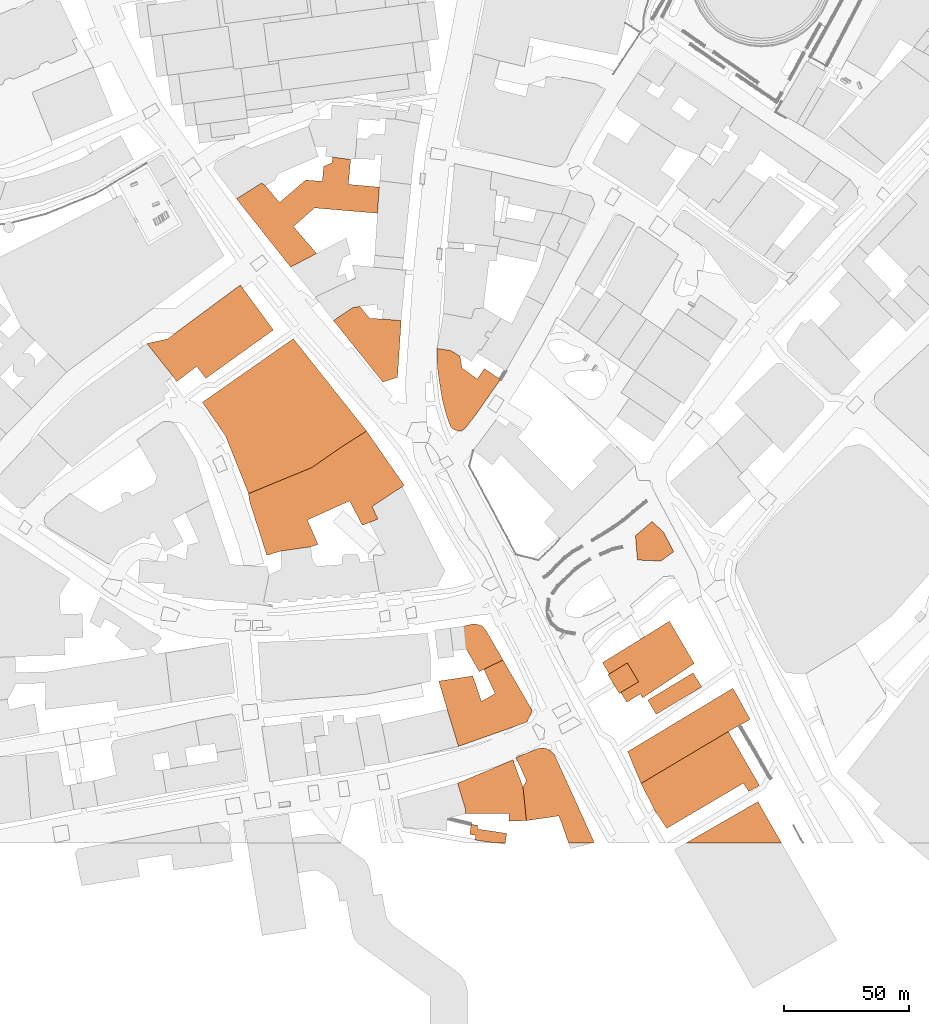
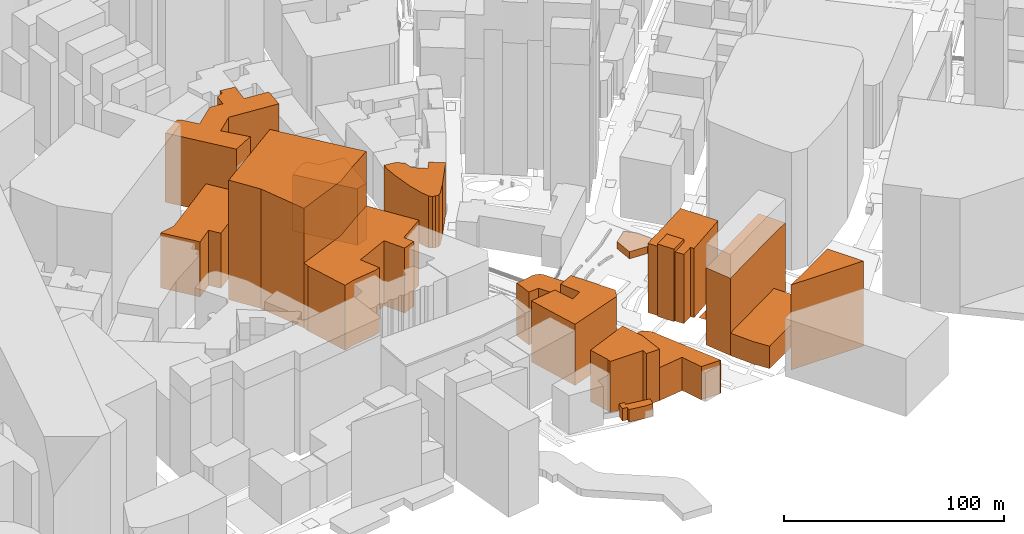
# One storey, part 101 of 200: 18 proxies.
"""IFC4 building model written with IfcOpenShell, lengths in metres."""

from ifc_helpers import new_model, si_unit, origin_with_axes, place, context, subcontext, project, spatial, triangles, material, element, save


model = new_model("IFC4")

# Units and contexts
model_context = context("Model", 3, precision=1e-05, world=origin_with_axes())
body_context = subcontext(model_context, "Body", "Model", "MODEL_VIEW")
ifc_project = project(units=[si_unit("VOLUMEUNIT", "CUBIC_METRE"), si_unit("LENGTHUNIT", "METRE"), si_unit("AREAUNIT", "SQUARE_METRE")], contexts=[model_context])

# Site, building, storey
site_placement = place(None, origin_with_axes())
site = spatial("IfcSite", under=ifc_project, at=site_placement)
building_placement = place(site_placement, origin_with_axes())
building = spatial("IfcBuilding", under=site, at=building_placement, Name="Building")
storey_placement = place(building_placement, origin_with_axes())
storey = spatial("IfcBuildingStorey", under=building, at=storey_placement, Name="Ground")

# Proxies
ifc_material_1 = material()
proxy_1_placement = place(storey_placement, origin_with_axes())
element("IfcBuildingElementProxy", 1, at=proxy_1_placement, inside=storey, material=ifc_material_1, Name="cw_buildings_UK 442", context=body_context, shape_type="Tessellation", body=[
    triangles([(348.2929526134377, -713.8784918243783, 31.215002059936523), (342.9966887310573, -688.4192587580843, 31.215002059936523), (339.09418499970246, -683.6805008354617, 31.215002059936523), (328.5945733121118, -689.3484195297851, 31.215002059936523), (355.6333986837714, -689.3484195297851, 31.215002059936523), (336.30667419438856, -684.145081221312, 31.215002059936523), (333.5191633890746, -695.4809376034334, 31.215002059936523), (354.1467224555758, -711.9272352103322, 31.215002059936523), (348.01420438192747, -688.6980069895945, 31.215002059936523), (354.1467224555758, -711.9272352103322, 0.0), (355.6333986837714, -689.3484195297851, 0.0), (348.2929526134377, -713.8784918243783, 0.0), (333.5191633890746, -695.4809376034334, 0.0), (328.5945733121118, -689.3484195297851, 0.0), (336.30667419438856, -684.145081221312, 0.0), (339.09418499970246, -683.6805008354617, 0.0), (342.9966887310573, -688.4192587580843, 0.0), (348.01420438192747, -688.6980069895945, 0.0)], [[1, 2, 3], [3, 4, 1], [1, 5, 2], [3, 6, 4], [4, 7, 1], [1, 8, 5], [5, 9, 2], [10, 11, 5], [10, 5, 8], [12, 10, 8], [12, 8, 1], [13, 12, 1], [13, 1, 7], [14, 13, 7], [14, 7, 4], [15, 14, 4], [15, 4, 6], [16, 15, 6], [16, 6, 3], [17, 16, 3], [17, 3, 2], [18, 17, 2], [18, 2, 9], [11, 18, 9], [11, 9, 5], [17, 18, 11], [11, 10, 12], [12, 13, 14], [14, 15, 16], [17, 11, 12], [12, 14, 16], [16, 17, 12]], closed=False),
])
proxy_2_placement = place(storey_placement, origin_with_axes())
element("IfcBuildingElementProxy", 2, at=proxy_2_placement, inside=storey, material=ifc_material_1, Name="cw_buildings_UK 443", context=body_context, shape_type="Tessellation", body=[
    triangles([(307.0378439771726, -642.2395505481192, 38.31364059448242), (321.0682998358065, -644.3766393165054, 38.31364059448242), (334.54124973468265, -634.9920205549555, 38.31364059448242), (324.134554124262, -633.7841115517446, 38.31364059448242), (312.61286083943185, -651.8099824705347, 38.31364059448242), (335.47042000312064, -625.0499243238597, 38.31364059448242), (299.9296975965013, -634.434524091935, 38.31364059448242), (346.1558638450515, -646.5137280848915, 38.31364059448242), (328.0370673523541, -626.3507494042407, 38.31364059448242), (311.49785841665374, -667.9775318459233, 38.31364059448242), (346.89920195914937, -636.1070324744709, 38.31364059448242), (328.2228995066942, -624.1207445586845, 38.31364059448242), (324.6920600840197, -627.8374256324364, 38.31364059448242), (317.53745566476334, -633.2265960952496, 38.31364059448242), (301.41636907632835, -635.4566199342803, 38.31364059448242), (289.89467104312956, -640.7528743199235, 38.31364059448242), (321.88132025941326, -662.5418843510506, 38.31364059448242), (289.89467104312956, -640.7528743199235, 0.0), (311.49785841665374, -667.9775318459233, 0.0), (299.9296975965013, -634.434524091935, 0.0), (301.41636907632835, -635.4566199342803, 0.0), (307.0378439771726, -642.2395505481192, 0.0), (317.53745566476334, -633.2265960952496, 0.0), (324.134554124262, -633.7841115517446, 0.0), (324.6920600840197, -627.8374256324364, 0.0), (328.0370673523541, -626.3507494042407, 0.0), (328.2228995066942, -624.1207445586845, 0.0), (335.47042000312064, -625.0499243238597, 0.0), (334.54124973468265, -634.9920205549555, 0.0), (346.89920195914937, -636.1070324744709, 0.0), (346.1558638450515, -646.5137280848915, 0.0), (321.0682998358065, -644.3766393165054, 0.0), (312.61286083943185, -651.8099824705347, 0.0), (321.88132025941326, -662.5418843510506, 0.0)], [[1, 2, 3], [3, 4, 1], [1, 5, 2], [3, 6, 4], [1, 7, 5], [2, 8, 3], [6, 9, 4], [7, 10, 5], [8, 11, 3], [6, 12, 9], [9, 13, 4], [4, 14, 1], [1, 15, 7], [7, 16, 10], [10, 17, 5], [18, 19, 10], [18, 10, 16], [20, 18, 16], [20, 16, 7], [21, 20, 7], [21, 7, 15], [22, 21, 15], [22, 15, 1], [23, 22, 1], [23, 1, 14], [24, 23, 14], [24, 14, 4], [25, 24, 4], [25, 4, 13], [26, 25, 13], [26, 13, 9], [27, 26, 9], [27, 9, 12], [28, 27, 12], [28, 12, 6], [29, 28, 6], [29, 6, 3], [30, 29, 3], [30, 3, 11], [31, 30, 11], [31, 11, 8], [32, 31, 8], [32, 8, 2], [33, 32, 2], [33, 2, 5], [34, 33, 5], [34, 5, 17], [19, 34, 17], [19, 17, 10], [33, 34, 19], [19, 18, 20], [20, 21, 22], [22, 23, 24], [24, 25, 26], [26, 27, 28], [29, 30, 31], [33, 19, 20], [24, 26, 28], [29, 31, 32], [33, 20, 22], [24, 28, 29], [32, 33, 22], [22, 24, 29], [29, 32, 22]], closed=False),
])
proxy_3_placement = place(storey_placement, origin_with_axes())
element("IfcBuildingElementProxy", 3, at=proxy_3_placement, inside=storey, material=ifc_material_1, Name="cw_buildings_UK 447", context=body_context, shape_type="Tessellation", body=[
    triangles([(262.34480487285015, -696.6888656001188, 30.53400230407715), (264.5748120925907, -711.555570901652, 30.53400230407715), (274.0523374345734, -707.5601415963898, 30.53400230407715), (304.6220022289076, -693.065100603537, 30.53400230407715), (254.1681152950779, -698.4542900598248, 30.53400230407715), (266.0614811982334, -713.6926596700381, 30.53400230407715), (277.67609768278663, -712.3918155961826, 30.53400230407715), (291.42780056154163, -675.1321267684424, 30.53400230407715), (304.6220022289076, -693.065100603537, 0.0), (291.42780056154163, -675.1321267684424, 0.0), (277.67609768278663, -712.3918155961826, 0.0), (274.0523374345734, -707.5601415963898, 0.0), (266.0614811982334, -713.6926596700381, 0.0), (264.5748120925907, -711.555570901652, 0.0), (254.1681152950779, -698.4542900598248, 0.0), (262.34480487285015, -696.6888656001188, 0.0)], [[1, 2, 3], [3, 4, 1], [1, 5, 2], [2, 6, 3], [3, 7, 4], [4, 8, 1], [9, 10, 8], [9, 8, 4], [11, 9, 4], [11, 4, 7], [12, 11, 7], [12, 7, 3], [13, 12, 3], [13, 3, 6], [14, 13, 6], [14, 6, 2], [15, 14, 2], [15, 2, 5], [16, 15, 5], [16, 5, 1], [10, 16, 1], [10, 1, 8], [16, 10, 9], [9, 11, 12], [12, 13, 14], [14, 15, 16], [16, 9, 12], [12, 14, 16]], closed=False),
])
proxy_4_placement = place(storey_placement, origin_with_axes())
element("IfcBuildingElementProxy", 4, at=proxy_4_placement, inside=storey, material=ifc_material_1, Name="cw_buildings_UK 450", context=body_context, shape_type="Tessellation", body=[
    triangles([(318.1878729533225, -768.8853223328729, 35.946388244628906), (335.0058396172703, -761.2661280310289, 35.946388244628906), (319.95329741302834, -747.9790150348615, 35.946388244628906), (307.5953451885617, -781.2897325959246, 35.946388244628906), (344.01877507666535, -763.4961138831106, 35.946388244628906), (295.0980188483399, -761.405502146784, 35.946388244628906), (319.58162835597943, -779.5707471813292, 35.946388244628906), (342.9734597117648, -769.8609411431587, 35.946388244628906), (341.7887702311091, -733.3910389713641, 35.946388244628906), (294.70312077199844, -758.3624816259896, 35.946388244628906), (301.99709930700993, -782.985469997753, 35.946388244628906), (322.46205523846345, -778.6415864096285, 35.946388244628906), (340.1162713453105, -771.0223921077845, 35.946388244628906), (346.3417054961289, -768.5136580241926, 35.946388244628906), (356.84131718371964, -755.040674886736, 35.946388244628906), (332.0324966576162, -739.6164921156569, 35.946388244628906), (356.84131718371964, -755.040674886736, 0.0), (341.7887702311091, -733.3910389713641, 0.0), (344.01877507666535, -763.4961138831106, 0.0), (346.3417054961289, -768.5136580241926, 0.0), (342.9734597117648, -769.8609411431587, 0.0), (340.1162713453105, -771.0223921077845, 0.0), (335.0058396172703, -761.2661280310289, 0.0), (318.1878729533225, -768.8853223328729, 0.0), (322.46205523846345, -778.6415864096285, 0.0), (319.58162835597943, -779.5707471813292, 0.0), (307.5953451885617, -781.2897325959246, 0.0), (301.99709930700993, -782.985469997753, 0.0), (295.0980188483399, -761.405502146784, 0.0), (294.70312077199844, -758.3624816259896, 0.0), (319.95329741302834, -747.9790150348615, 0.0), (332.0324966576162, -739.6164921156569, 0.0)], [[1, 2, 3], [3, 4, 1], [2, 5, 3], [3, 6, 4], [4, 7, 1], [2, 8, 5], [5, 9, 3], [3, 10, 6], [6, 11, 4], [7, 12, 1], [2, 13, 8], [8, 14, 5], [5, 15, 9], [9, 16, 3], [17, 18, 9], [17, 9, 15], [19, 17, 15], [19, 15, 5], [20, 19, 5], [20, 5, 14], [21, 20, 14], [21, 14, 8], [22, 21, 8], [22, 8, 13], [23, 22, 13], [23, 13, 2], [24, 23, 2], [24, 2, 1], [25, 24, 1], [25, 1, 12], [26, 25, 12], [26, 12, 7], [27, 26, 7], [27, 7, 4], [28, 27, 4], [28, 4, 11], [29, 28, 11], [29, 11, 6], [30, 29, 6], [30, 6, 10], [31, 30, 10], [31, 10, 3], [32, 31, 3], [32, 3, 16], [18, 32, 16], [18, 16, 9], [31, 32, 18], [18, 17, 19], [19, 20, 21], [21, 22, 23], [24, 25, 26], [27, 28, 29], [29, 30, 31], [31, 18, 19], [19, 21, 23], [24, 26, 27], [27, 29, 31], [31, 19, 23], [24, 27, 31], [31, 23, 24]], closed=False),
])
proxy_5_placement = place(storey_placement, origin_with_axes())
element("IfcBuildingElementProxy", 5, at=proxy_5_placement, inside=storey, material=ifc_material_1, Name="cw_buildings_UK 454", context=body_context, shape_type="Tessellation", body=[
    triangles([(381.0926317500654, -732.3689621224933, 28.69000244140625), (379.9079422694097, -708.2802411944579, 28.69000244140625), (369.8496819483768, -704.679724210643, 28.69000244140625), (375.3317779850974, -731.8114656594728, 28.69000244140625), (385.994002304473, -712.6705638276928, 28.69000244140625), (379.09491709743435, -703.6111703297128, 28.69000244140625), (371.98677071676303, -720.8472545925573, 28.69000244140625), (378.1192887904113, -733.298122894194, 28.69000244140625), (395.19276991820817, -712.833185956215, 28.69000244140625), (369.9425980255469, -700.4984627510408, 28.69000244140625), (370.31427183096446, -710.2547268277965, 28.69000244140625), (373.7521951764689, -727.4443720455304, 28.69000244140625), (376.72553813612296, -732.9264585855137, 28.69000244140625), (379.7917971729471, -733.298122894194, 28.69000244140625), (385.2971222289602, -727.0030016854981, 28.69000244140625), (388.78150361304967, -708.4428443295055, 28.69000244140625), (375.3317779850974, -701.2417913684014, 28.69000244140625), (369.8961399869619, -702.2638682172721, 28.69000244140625), (375.3317779850974, -701.2417913684014, 0.0), (369.9425980255469, -700.4984627510408, 0.0), (379.09491709743435, -703.6111703297128, 0.0), (379.9079422694097, -708.2802411944579, 0.0), (385.994002304473, -712.6705638276928, 0.0), (388.78150361304967, -708.4428443295055, 0.0), (395.19276991820817, -712.833185956215, 0.0), (385.2971222289602, -727.0030016854981, 0.0), (381.0926317500654, -732.3689621224933, 0.0), (379.7917971729471, -733.298122894194, 0.0), (378.1192887904113, -733.298122894194, 0.0), (376.72553813612296, -732.9264585855137, 0.0), (375.3317779850974, -731.8114656594728, 0.0), (373.7521951764689, -727.4443720455304, 0.0), (371.98677071676303, -720.8472545925573, 0.0), (370.31427183096446, -710.2547268277965, 0.0), (369.8496819483768, -704.679724210643, 0.0), (369.8961399869619, -702.2638682172721, 0.0)], [[1, 2, 3], [3, 4, 1], [1, 5, 2], [2, 6, 3], [3, 7, 4], [4, 8, 1], [1, 9, 5], [6, 10, 3], [3, 11, 7], [7, 12, 4], [4, 13, 8], [8, 14, 1], [1, 15, 9], [9, 16, 5], [6, 17, 10], [10, 18, 3], [19, 20, 10], [19, 10, 17], [21, 19, 17], [21, 17, 6], [22, 21, 6], [22, 6, 2], [23, 22, 2], [23, 2, 5], [24, 23, 5], [24, 5, 16], [25, 24, 16], [25, 16, 9], [26, 25, 9], [26, 9, 15], [27, 26, 15], [27, 15, 1], [28, 27, 1], [28, 1, 14], [29, 28, 14], [29, 14, 8], [30, 29, 8], [30, 8, 13], [31, 30, 13], [31, 13, 4], [32, 31, 4], [32, 4, 12], [33, 32, 12], [33, 12, 7], [34, 33, 7], [34, 7, 11], [35, 34, 11], [35, 11, 3], [36, 35, 3], [36, 3, 18], [20, 36, 18], [20, 18, 10], [35, 36, 20], [20, 19, 21], [23, 24, 25], [25, 26, 27], [27, 28, 29], [29, 30, 31], [31, 32, 33], [33, 34, 35], [35, 20, 21], [23, 25, 27], [27, 29, 31], [31, 33, 35], [35, 21, 22], [22, 23, 27], [27, 31, 35], [35, 22, 27]], closed=False),
])
proxy_6_placement = place(storey_placement, origin_with_axes())
element("IfcBuildingElementProxy", 6, at=proxy_6_placement, inside=storey, material=ifc_material_1, Name="cw_buildings_UK 511", context=body_context, shape_type="Tessellation", body=[
    triangles([(464.29973859484556, -781.5452328146678, 3.910000801086426), (455.70492548271585, -769.4892768344783, 3.910000801086426), (449.87438465987026, -784.8670015669725, 3.910000801086426), (459.1892973700681, -785.2851619011867, 3.910000801086426), (460.327538308876, -773.7634543712508, 3.910000801086426), (449.08457901045017, -775.1571955288018, 3.910000801086426), (460.327538308876, -773.7634543712508, 0.0), (455.70492548271585, -769.4892768344783, 0.0), (464.29973859484556, -781.5452328146678, 0.0), (459.1892973700681, -785.2851619011867, 0.0), (449.87438465987026, -784.8670015669725, 0.0), (449.08457901045017, -775.1571955288018, 0.0)], [[1, 2, 3], [3, 4, 1], [1, 5, 2], [2, 6, 3], [7, 8, 2], [7, 2, 5], [9, 7, 5], [9, 5, 1], [10, 9, 1], [10, 1, 4], [11, 10, 4], [11, 4, 3], [12, 11, 3], [12, 3, 6], [8, 12, 6], [8, 6, 2], [11, 12, 8], [8, 7, 9], [9, 10, 11], [11, 8, 9]], closed=False),
])
proxy_7_placement = place(storey_placement, origin_with_axes())
element("IfcBuildingElementProxy", 7, at=proxy_7_placement, inside=storey, material=ifc_material_1, Name="cw_buildings_UK 519", context=body_context, shape_type="Tessellation", body=[
    triangles([(341.7887702311091, -733.3910389713641, 66.19275665283203), (285.4811193906021, -735.2958565402996, 66.19275665283203), (294.70312077199844, -758.3624816259896, 66.19275665283203), (332.0324966576162, -739.6164921156569, 66.19275665283203), (276.3055712994222, -721.9390374927801, 66.19275665283203), (319.95329741302834, -747.9790150348615, 66.19275665283203), (312.56640280084684, -696.5262624650712, 66.19275665283203), (332.0324966576162, -739.6164921156569, 0.0), (341.7887702311091, -733.3910389713641, 0.0), (319.95329741302834, -747.9790150348615, 0.0), (294.70312077199844, -758.3624816259896, 0.0), (285.4811193906021, -735.2958565402996, 0.0), (276.3055712994222, -721.9390374927801, 0.0), (312.56640280084684, -696.5262624650712, 0.0)], [[1, 2, 3], [3, 4, 1], [1, 5, 2], [3, 6, 4], [1, 7, 5], [8, 9, 1], [8, 1, 4], [10, 8, 4], [10, 4, 6], [11, 10, 6], [11, 6, 3], [12, 11, 3], [12, 3, 2], [13, 12, 2], [13, 2, 5], [14, 13, 5], [14, 5, 7], [9, 14, 7], [9, 7, 1], [13, 14, 9], [8, 10, 11], [12, 13, 9], [9, 8, 11], [11, 12, 9]], closed=False),
])
proxy_8_placement = place(storey_placement, origin_with_axes())
element("IfcBuildingElementProxy", 8, at=proxy_8_placement, inside=storey, material=ifc_material_1, Name="cw_buildings_UK 711", context=body_context, shape_type="Tessellation", body=[
    triangles([(451.9185573510864, -815.9419229815255, 38.32500076293945), (440.39684982115034, -834.4091595119794, 38.32500076293945), (451.0126066052037, -838.2884437207789, 38.32500076293945), (451.9417863703789, -839.868031277776, 38.32500076293945), (438.654654380737, -830.2743608393307, 38.32500076293945), (443.2308281617866, -837.7077134900974, 38.32500076293945), (462.60400119301727, -809.2519060706725, 38.32500076293945), (435.8903820914528, -825.7911173805571, 38.32500076293945), (438.0971579177166, -830.6227961287185, 38.32500076293945), (442.6036256474141, -838.1026068180702, 38.32500076293945), (445.62343614239046, -841.6102219698207, 38.32500076293945), (472.54611641758754, -826.1627840634218, 38.32500076293945), (451.0126066052037, -838.2884437207789, 0.0), (451.9417863703789, -839.868031277776, 0.0), (445.62343614239046, -841.6102219698207, 0.0), (443.2308281617866, -837.7077134900974, 0.0), (442.6036256474141, -838.1026068180702, 0.0), (440.39684982115034, -834.4091595119794, 0.0), (438.0971579177166, -830.6227961287185, 0.0), (438.654654380737, -830.2743608393307, 0.0), (435.8903820914528, -825.7911173805571, 0.0), (451.9185573510864, -815.9419229815255, 0.0), (462.60400119301727, -809.2519060706725, 0.0), (472.54611641758754, -826.1627840634218, 0.0)], [[1, 2, 3], [3, 4, 1], [1, 5, 2], [2, 6, 3], [4, 7, 1], [1, 8, 5], [5, 9, 2], [2, 10, 6], [6, 11, 3], [4, 12, 7], [13, 14, 4], [13, 4, 3], [15, 13, 3], [15, 3, 11], [16, 15, 11], [16, 11, 6], [17, 16, 6], [17, 6, 10], [18, 17, 10], [18, 10, 2], [19, 18, 2], [19, 2, 9], [20, 19, 9], [20, 9, 5], [21, 20, 5], [21, 5, 8], [22, 21, 8], [22, 8, 1], [23, 22, 1], [23, 1, 7], [24, 23, 7], [24, 7, 12], [14, 24, 12], [14, 12, 4], [23, 24, 14], [13, 15, 16], [16, 17, 18], [18, 19, 20], [20, 21, 22], [22, 23, 14], [13, 16, 18], [18, 20, 22], [22, 14, 13], [13, 18, 22]], closed=False),
])
proxy_9_placement = place(storey_placement, origin_with_axes())
element("IfcBuildingElementProxy", 9, at=proxy_9_placement, inside=storey, material=ifc_material_1, Name="cw_buildings_UK 712", context=body_context, shape_type="Tessellation", body=[
    triangles([(494.86939389244253, -848.4628443899057, 42.794002532958984), (445.97187143177825, -861.2853817485915, 42.794002532958984), (486.1584356838502, -853.2480650994821, 42.794002532958984), (490.5719873363777, -850.8322280995858, 42.794002532958984), (487.9703181821411, -835.9887470689765, 42.794002532958984), (451.2913738301884, -874.0149982817384, 42.794002532958984), (487.9703181821411, -835.9887470689765, 0.0), (445.97187143177825, -861.2853817485915, 0.0), (494.86939389244253, -848.4628443899057, 0.0), (490.5719873363777, -850.8322280995858, 0.0), (486.1584356838502, -853.2480650994821, 0.0), (451.2913738301884, -874.0149982817384, 0.0)], [[1, 2, 3], [3, 4, 1], [1, 5, 2], [2, 6, 3], [7, 8, 2], [7, 2, 5], [9, 7, 5], [9, 5, 1], [10, 9, 1], [10, 1, 4], [11, 10, 4], [11, 4, 3], [12, 11, 3], [12, 3, 6], [8, 12, 6], [8, 6, 2], [11, 12, 8], [8, 7, 9], [9, 10, 11], [11, 8, 9]], closed=False),
])
proxy_10_placement = place(storey_placement, origin_with_axes())
element("IfcBuildingElementProxy", 10, at=proxy_10_placement, inside=storey, material=ifc_material_1, Name="cw_buildings_UK 720", context=body_context, shape_type="Tessellation", body=[
    triangles([(398.6074737411574, -886.0709732554024, 28.537002563476562), (398.70038981832744, -888.9513906411491, 28.537002563476562), (400.2102855690784, -864.5839309783407, 28.537002563476562), (381.2320058658205, -884.2126327185264, 28.537002563476562), (405.5994750253661, -888.8352455446865, 28.537002563476562), (381.32492194299056, -886.0709732554024, 28.537002563476562), (402.3938323760496, -888.904932602564, 28.537002563476562), (404.2057148743405, -875.4552069746118, 28.537002563476562), (378.1192887904113, -873.8756241659833, 28.537002563476562), (400.2102855690784, -864.5839309783407, 0.0), (378.1192887904113, -873.8756241659833, 0.0), (404.2057148743405, -875.4552069746118, 0.0), (405.5994750253661, -888.8352455446865, 0.0), (402.3938323760496, -888.904932602564, 0.0), (398.70038981832744, -888.9513906411491, 0.0), (398.6074737411574, -886.0709732554024, 0.0), (381.32492194299056, -886.0709732554024, 0.0), (381.2320058658205, -884.2126327185264, 0.0)], [[1, 2, 3], [3, 4, 1], [2, 5, 3], [4, 6, 1], [2, 7, 5], [5, 8, 3], [3, 9, 4], [10, 11, 9], [10, 9, 3], [12, 10, 3], [12, 3, 8], [13, 12, 8], [13, 8, 5], [14, 13, 5], [14, 5, 7], [15, 14, 7], [15, 7, 2], [16, 15, 2], [16, 2, 1], [17, 16, 1], [17, 1, 6], [18, 17, 6], [18, 6, 4], [11, 18, 4], [11, 4, 9], [18, 11, 10], [10, 12, 13], [13, 14, 15], [16, 17, 18], [10, 13, 15], [16, 18, 10], [10, 15, 16]], closed=False),
])
proxy_11_placement = place(storey_placement, origin_with_axes())
element("IfcBuildingElementProxy", 11, at=proxy_11_placement, inside=storey, material=ifc_material_1, Name="cw_buildings_UK 728", context=body_context, shape_type="Tessellation", body=[
    triangles([(486.73916116616317, -854.4095303092139, 12.42500114440918), (486.1584356838502, -853.2480650994821, 12.42500114440918), (492.1748086610359, -873.8988531852758, 12.42500114440918), (495.45013836823, -869.4620725134558, 12.42500114440918), (456.81991840875673, -884.8165872201319, 12.42500114440918), (498.5860749661945, -874.8047944344213, 12.42500114440918), (490.362926162745, -860.5885064214473, 12.42500114440918), (451.2913738301884, -874.0149982817384, 12.42500114440918), (461.55867633137944, -891.9247336008032, 12.42500114440918), (494.26543939083706, -877.2206314343176, 12.42500114440918), (461.55867633137944, -891.9247336008032, 0.0), (492.1748086610359, -873.8988531852758, 0.0), (456.81991840875673, -884.8165872201319, 0.0), (451.2913738301884, -874.0149982817384, 0.0), (486.1584356838502, -853.2480650994821, 0.0), (486.73916116616317, -854.4095303092139, 0.0), (490.362926162745, -860.5885064214473, 0.0), (495.45013836823, -869.4620725134558, 0.0), (498.5860749661945, -874.8047944344213, 0.0), (494.26543939083706, -877.2206314343176, 0.0)], [[1, 2, 3], [3, 4, 1], [2, 5, 3], [3, 6, 4], [4, 7, 1], [2, 8, 5], [5, 9, 3], [3, 10, 6], [11, 12, 3], [11, 3, 9], [13, 11, 9], [13, 9, 5], [14, 13, 5], [14, 5, 8], [15, 14, 8], [15, 8, 2], [16, 15, 2], [16, 2, 1], [17, 16, 1], [17, 1, 7], [18, 17, 7], [18, 7, 4], [19, 18, 4], [19, 4, 6], [20, 19, 6], [20, 6, 10], [12, 20, 10], [12, 10, 3], [19, 20, 12], [12, 11, 13], [13, 14, 15], [16, 17, 18], [18, 19, 12], [12, 13, 15], [16, 18, 12], [12, 15, 16]], closed=False),
])
proxy_12_placement = place(storey_placement, origin_with_axes())
element("IfcBuildingElementProxy", 12, at=proxy_12_placement, inside=storey, material=ifc_material_1, Name="cw_buildings_UK 729", context=body_context, shape_type="Tessellation", body=[
    triangles([(405.92468129546137, -849.4849307355138, 33.8280029296875), (393.1021391884071, -838.1722986243163, 33.8280029296875), (387.6200431516865, -841.2385529127719, 33.8280029296875), (373.93802733080906, -844.4209617944272, 33.8280029296875), (396.2380852831088, -824.7225729963641, 33.8280029296875), (384.1821198061821, -831.11061028223, 33.8280029296875), (407.8759379095074, -844.8623131609851, 33.8280029296875), (388.61890047800205, -828.4624783410399, 33.8280029296875), (370.6162490817672, -833.1547829734461, 33.8280029296875), (378.4677240797991, -859.1947510187903, 33.8280029296875), (384.1821198061821, -831.11061028223, 0.0), (370.6162490817672, -833.1547829734461, 0.0), (387.6200431516865, -841.2385529127719, 0.0), (393.1021391884071, -838.1722986243163, 0.0), (388.61890047800205, -828.4624783410399, 0.0), (396.2380852831088, -824.7225729963641, 0.0), (407.8759379095074, -844.8623131609851, 0.0), (405.92468129546137, -849.4849307355138, 0.0), (378.4677240797991, -859.1947510187903, 0.0), (373.93802733080906, -844.4209617944272, 0.0)], [[1, 2, 3], [3, 4, 1], [1, 5, 2], [3, 6, 4], [1, 7, 5], [5, 8, 2], [6, 9, 4], [4, 10, 1], [11, 12, 9], [11, 9, 6], [13, 11, 6], [13, 6, 3], [14, 13, 3], [14, 3, 2], [15, 14, 2], [15, 2, 8], [16, 15, 8], [16, 8, 5], [17, 16, 5], [17, 5, 7], [18, 17, 7], [18, 7, 1], [19, 18, 1], [19, 1, 10], [20, 19, 10], [20, 10, 4], [12, 20, 4], [12, 4, 9], [18, 19, 20], [20, 12, 11], [14, 15, 16], [16, 17, 18], [20, 11, 13], [14, 16, 18], [18, 20, 13], [13, 14, 18]], closed=False),
])
proxy_13_placement = place(storey_placement, origin_with_axes())
element("IfcBuildingElementProxy", 13, at=proxy_13_placement, inside=storey, material=ifc_material_1, Name="cw_buildings_UK 731", context=body_context, shape_type="Tessellation", body=[
    triangles([(389.2693225149298, -812.6433737517762, 29.238000869750977), (380.7209674413851, -811.1799312912417, 29.238000869750977), (381.65012821308585, -820.5180825174692, 29.238000869750977), (386.7605599411261, -829.3684195901853, 29.238000869750977), (386.0172313237655, -810.5062826092058, 29.238000869750977), (375.2156328886348, -811.9464960504478, 29.238000869750977), (396.2380852831088, -824.7225729963641, 29.238000869750977), (387.87556236390424, -811.1567022719491, 29.238000869750977), (384.25180686405963, -810.3204504548655, 29.238000869750977), (376.35386433070545, -821.0523547095657, 29.238000869750977), (380.7209674413851, -811.1799312912417, 0.0), (375.2156328886348, -811.9464960504478, 0.0), (384.25180686405963, -810.3204504548655, 0.0), (386.0172313237655, -810.5062826092058, 0.0), (387.87556236390424, -811.1567022719491, 0.0), (389.2693225149298, -812.6433737517762, 0.0), (396.2380852831088, -824.7225729963641, 0.0), (386.7605599411261, -829.3684195901853, 0.0), (381.65012821308585, -820.5180825174692, 0.0), (376.35386433070545, -821.0523547095657, 0.0)], [[1, 2, 3], [3, 4, 1], [1, 5, 2], [2, 6, 3], [4, 7, 1], [1, 8, 5], [5, 9, 2], [6, 10, 3], [11, 12, 6], [11, 6, 2], [13, 11, 2], [13, 2, 9], [14, 13, 9], [14, 9, 5], [15, 14, 5], [15, 5, 8], [16, 15, 8], [16, 8, 1], [17, 16, 1], [17, 1, 7], [18, 17, 7], [18, 7, 4], [19, 18, 4], [19, 4, 3], [20, 19, 3], [20, 3, 10], [12, 20, 10], [12, 10, 6], [19, 20, 12], [11, 13, 14], [14, 15, 16], [16, 17, 18], [19, 12, 11], [11, 14, 16], [16, 18, 19], [19, 11, 16]], closed=False),
])
proxy_14_placement = place(storey_placement, origin_with_axes())
element("IfcBuildingElementProxy", 14, at=proxy_14_placement, inside=storey, material=ifc_material_1, Name="cw_buildings_UK 732", context=body_context, shape_type="Tessellation", body=[
    triangles([(450.33896504572067, -833.433535953325, 40.12200164794922), (438.654654380737, -830.2743608393307, 40.12200164794922), (440.39684982115034, -834.4091595119794, 40.12200164794922), (443.2308281617866, -837.7077134900974, 40.12200164794922), (445.83249731602314, -825.9304914963122, 40.12200164794922), (438.0971579177166, -830.6227961287185, 40.12200164794922), (442.6036256474141, -838.1026068180702, 40.12200164794922), (440.39684982115034, -834.4091595119794, 0.0), (442.6036256474141, -838.1026068180702, 0.0), (438.0971579177166, -830.6227961287185, 0.0), (438.654654380737, -830.2743608393307, 0.0), (445.83249731602314, -825.9304914963122, 0.0), (450.33896504572067, -833.433535953325, 0.0), (443.2308281617866, -837.7077134900974, 0.0)], [[1, 2, 3], [3, 4, 1], [1, 5, 2], [2, 6, 3], [3, 7, 4], [8, 9, 7], [8, 7, 3], [10, 8, 3], [10, 3, 6], [11, 10, 6], [11, 6, 2], [12, 11, 2], [12, 2, 5], [13, 12, 5], [13, 5, 1], [14, 13, 1], [14, 1, 4], [9, 14, 4], [9, 4, 7], [14, 9, 8], [8, 10, 11], [11, 12, 13], [13, 14, 8], [8, 11, 13]], closed=False),
])
proxy_15_placement = place(storey_placement, origin_with_axes())
element("IfcBuildingElementProxy", 15, at=proxy_15_placement, inside=storey, material=ifc_material_1, Name="cw_buildings_UK 831", context=body_context, shape_type="Tessellation", body=[
    triangles([(497.93566242600394, -881.2392897588724, 0.0), (497.93566242600394, -881.2392897588724, 47.1400032043457), (507.30980273241585, -897.6930708238181, 27.241125827804645), (469.34547106637757, -897.6930708238181, 40.37523594129565), (507.30980273241585, -897.6930708238181, 0.0), (469.34547106637757, -897.6930708238181, 47.1400032043457), (497.5200847873953, -897.6930708238181, 47.1400032043457), (507.30980273241585, -897.6930708238181, 47.1400032043457), (469.34547106637757, -897.6930708238181, 0.0), (497.5200847873953, -897.6930708238181, 0.0)], [[1, 2, 3], [2, 1, 4], [3, 5, 1], [4, 6, 2], [2, 7, 8], [2, 6, 7], [2, 8, 3], [1, 9, 4], [1, 10, 9], [1, 5, 10], [10, 5, 3], [3, 8, 7], [7, 6, 4], [4, 9, 10], [10, 3, 7], [7, 4, 10]], closed=False),
])
proxy_16_placement = place(storey_placement, origin_with_axes())
element("IfcBuildingElementProxy", 16, at=proxy_16_placement, inside=storey, material=ifc_material_1, Name="cw_buildings_UK 832", context=body_context, shape_type="Tessellation", body=[
    triangles([(385.9475442658879, -892.1802528130208, 6.892002105712891), (383.5549267885468, -890.2986927535896, 6.892002105712891), (385.34358026754524, -894.6890153868246, 6.892002105712891), (386.1798344588131, -890.6935860815624, 6.892002105712891), (382.97420130623385, -894.3405800974368, 6.892002105712891), (385.34358026754524, -894.6890153868246, 0.0), (385.064832036035, -896.5473559237006, 0.0), (385.064832036035, -896.5473559237006, 6.892002105712891), (382.97420130623385, -894.3405800974368, 0.0), (383.5549267885468, -890.2986927535896, 0.0), (386.1798344588131, -890.6935860815624, 0.0), (385.9475442658879, -892.1802528130208, 0.0), (397.72476151130445, -893.8992192341417, 0.0), (397.72476151130445, -893.8992192341417, 6.892002105712891), (395.0682570501962, -897.6930708238181, 6.892002105712891), (392.8587342651417, -897.6930708238181, 6.892002105712891), (395.94996028670465, -897.6930708238181, 6.892002105712891), (397.16566424157025, -897.6930708238181, 0.9676955147074731), (392.8587342651417, -897.6930708238181, 4.472755510624115), (397.16566424157025, -897.6930708238181, 0.0), (395.0682570501962, -897.6930708238181, 0.0), (395.94996028670465, -897.6930708238181, 0.0), (397.16566424157025, -897.6930708238181, 6.892002105712891), (392.8587342651417, -897.6930708238181, 0.0)], [[1, 2, 3], [1, 4, 2], [2, 5, 3], [6, 7, 8], [6, 8, 3], [9, 6, 3], [9, 3, 5], [10, 9, 5], [10, 5, 2], [11, 10, 2], [11, 2, 4], [12, 11, 4], [12, 4, 1], [13, 12, 1], [13, 1, 14], [6, 9, 10], [10, 11, 12], [6, 10, 12], [1, 3, 15], [3, 8, 16], [14, 1, 17], [13, 14, 18], [8, 7, 19], [12, 13, 20], [7, 6, 21], [6, 12, 22], [15, 17, 1], [16, 15, 3], [17, 23, 14], [18, 20, 13], [19, 16, 8], [20, 22, 12], [21, 24, 7], [22, 21, 6], [14, 23, 18], [7, 24, 19], [19, 24, 21], [22, 20, 18], [18, 23, 17], [15, 16, 19], [19, 21, 22], [22, 18, 17], [17, 15, 19], [19, 22, 17]], closed=False),
])
proxy_17_placement = place(storey_placement, origin_with_axes())
element("IfcBuildingElementProxy", 17, at=proxy_17_placement, inside=storey, material=ifc_material_1, Name="cw_buildings_UK 833", context=body_context, shape_type="Tessellation", body=[
    triangles([(418.4916946935607, -886.9536759885181, 18.338001251220703), (419.44408448455397, -889.3695224851517, 18.338001251220703), (413.799394809523, -860.1239212872283, 18.338001251220703), (405.5762460060736, -872.8767668396678, 18.338001251220703), (404.2057148743405, -875.4552069746118, 18.338001251220703), (409.85042354284593, -860.1471503065208, 18.338001251220703), (405.5994750253661, -888.8352455446865, 18.338001251220703), (416.93533140748747, -862.8185112670035, 18.338001251220703), (415.61125831433947, -861.2621527292989, 18.338001251220703), (411.82490917618446, -859.7522522301794, 18.338001251220703), (401.3949845464713, -863.6779897291954, 18.338001251220703), (409.85042354284593, -860.1471503065208, 0.0), (401.3949845464713, -863.6779897291954, 0.0), (411.82490917618446, -859.7522522301794, 0.0), (413.799394809523, -860.1239212872283, 0.0), (415.61125831433947, -861.2621527292989, 0.0), (416.93533140748747, -862.8185112670035, 0.0), (432.6615294163183, -897.5694422693086, 0.0), (432.6615294163183, -897.5694422693086, 18.338001251220703), (419.44408448455397, -889.3695224851517, 0.0), (420.86107365487203, -893.4114098289989, 0.0), (420.86107365487203, -893.4114098289989, 18.338001251220703), (418.4916946935607, -886.9536759885181, 0.0), (405.5994750253661, -888.8352455446865, 0.0), (404.2057148743405, -875.4552069746118, 0.0), (405.5762460060736, -872.8767668396678, 0.0), (422.3818109164166, -897.6930708238181, 18.338001251220703), (422.65590869004086, -897.6930708238181, 18.338001251220703), (422.3784334421214, -897.6930708238181, 18.338001251220703), (422.8130663142525, -897.6930708238181, 18.338001251220703), (432.18684131270794, -897.6930708238181, 17.41727463160383), (422.3784334421214, -897.6930708238181, 11.860003139094452), (432.18684131270794, -897.6930708238181, 0.0), (422.3818109164166, -897.6930708238181, 0.0), (422.8130663142525, -897.6930708238181, 0.0), (422.65590869004086, -897.6930708238181, 0.0), (432.18684131270794, -897.6930708238181, 18.338001251220703), (422.3784334421214, -897.6930708238181, 0.0)], [[1, 2, 3], [3, 4, 1], [4, 5, 1], [3, 6, 4], [5, 7, 1], [8, 9, 3], [3, 10, 6], [6, 11, 4], [12, 13, 11], [12, 11, 6], [14, 12, 6], [14, 6, 10], [15, 14, 10], [15, 10, 3], [16, 15, 3], [16, 3, 9], [17, 16, 9], [17, 9, 8], [18, 17, 8], [18, 8, 19], [20, 21, 22], [20, 22, 2], [23, 20, 2], [23, 2, 1], [24, 23, 1], [24, 1, 7], [25, 24, 7], [25, 7, 5], [26, 25, 5], [26, 5, 4], [13, 26, 4], [13, 4, 11], [26, 13, 12], [12, 14, 15], [15, 16, 17], [23, 24, 25], [26, 12, 15], [23, 25, 26], [23, 26, 15], [15, 20, 23], [3, 2, 27], [8, 3, 28], [2, 22, 29], [19, 8, 30], [18, 19, 31], [22, 21, 32], [17, 18, 33], [21, 20, 34], [15, 17, 35], [20, 15, 36], [27, 28, 3], [28, 30, 8], [29, 27, 2], [30, 37, 19], [31, 33, 18], [32, 29, 22], [33, 35, 17], [34, 38, 21], [35, 36, 15], [36, 34, 20], [19, 37, 31], [21, 38, 32], [35, 33, 31], [31, 37, 30], [27, 29, 32], [32, 38, 34], [36, 35, 31], [31, 30, 28], [28, 27, 32], [32, 34, 36], [36, 31, 28], [28, 32, 36]], closed=False),
])
ifc_material_2 = material(Name="buildingConstruction")
proxy_18_placement = place(storey_placement, origin_with_axes())
element("IfcBuildingElementProxy", 18, at=proxy_18_placement, inside=storey, material=ifc_material_2, Name="cw_surface_buildingConstruction_3", ObjectType="Building Construction", context=body_context, shape_type="Tessellation", body=[
    triangles([(457.4006438910697, -846.4186716986896, 0.0), (475.49622086121184, -835.45447487688, 0.0), (472.0815170382627, -829.8330047244043, 0.0), (453.985959061595, -840.797201546214, 0.0)], [[1, 2, 3], [3, 4, 1]], closed=True),
])

save(model, "model.ifc")
